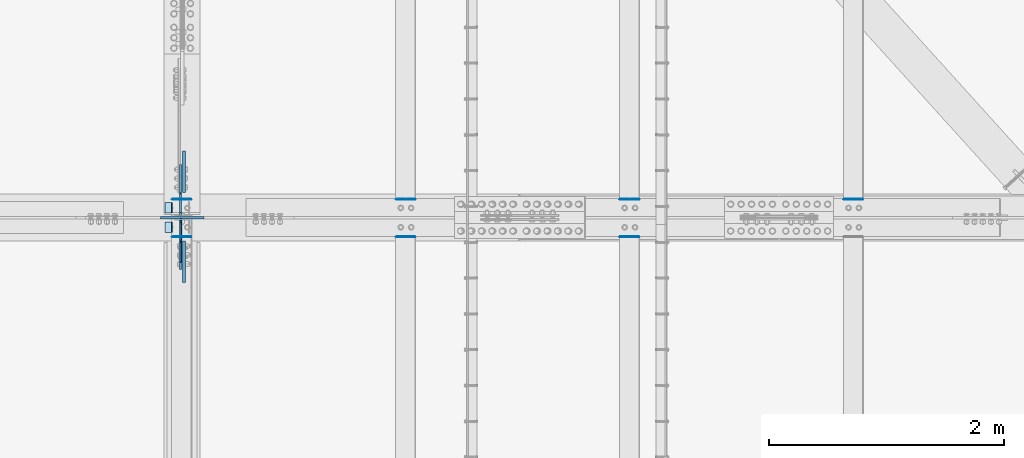
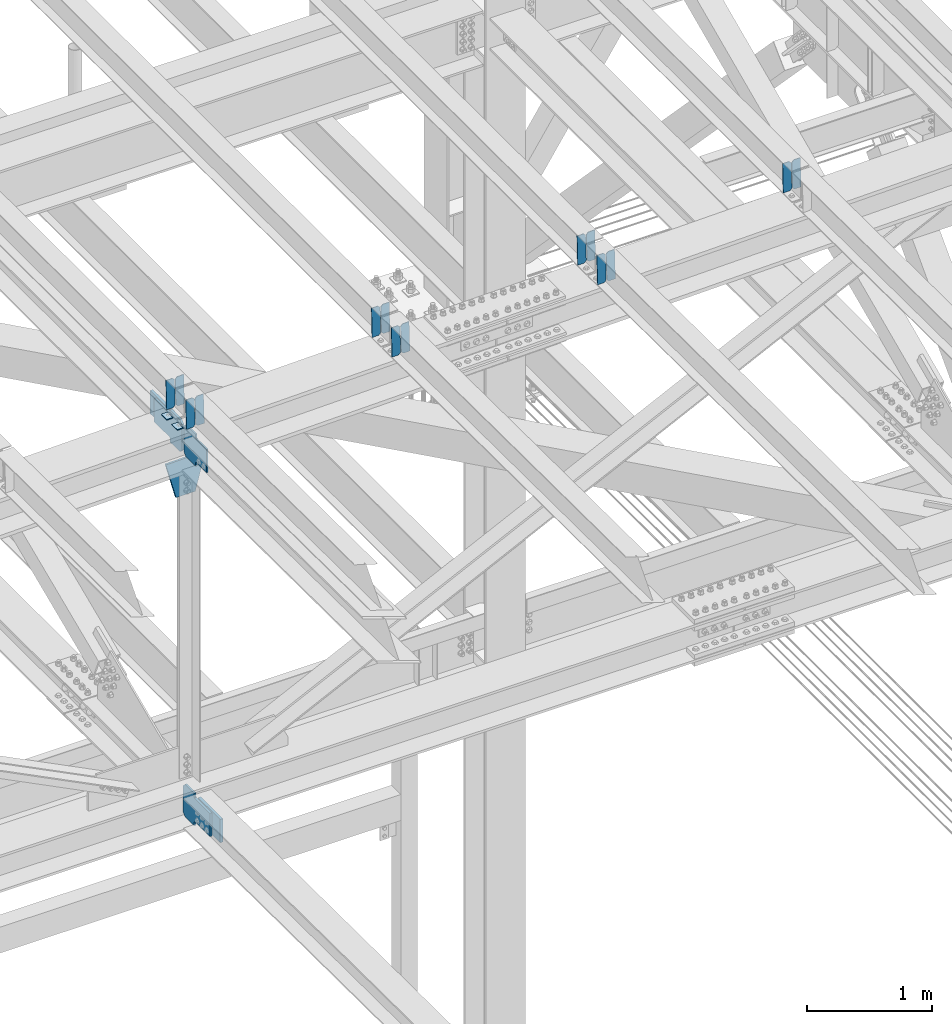
# One storey, part 3485 of 3843: 22 plates, 11 elements without a shape of their own.
"""IFC2X3 building model written with IfcOpenShell, lengths in millimetres."""

from ifc_helpers import new_model, si_unit, frame, origin_with_axes, place, context, subcontext, project, spatial, faceted_brep, material, type_object, element, aggregate, save


model = new_model("IFC2X3")

# Units and contexts
model_context = context("Model", 3, precision=1e-05, world=origin_with_axes())
body_context = subcontext(model_context, "Body", "Model", "MODEL_VIEW")
ifc_project = project(units=[si_unit("LENGTHUNIT", "METRE", prefix="MILLI"), si_unit("AREAUNIT", "SQUARE_METRE"), si_unit("VOLUMEUNIT", "CUBIC_METRE"), si_unit("MASSUNIT", "GRAM", prefix="KILO"), si_unit("TIMEUNIT", "SECOND"), si_unit("PLANEANGLEUNIT", "RADIAN"), si_unit("SOLIDANGLEUNIT", "STERADIAN"), si_unit("THERMODYNAMICTEMPERATUREUNIT", "DEGREE_CELSIUS"), si_unit("LUMINOUSINTENSITYUNIT", "LUMEN")], contexts=[model_context])

# Site, building, storey
site_placement = place(None, origin_with_axes())
site = spatial("IfcSite", under=ifc_project, at=site_placement, CompositionType="ELEMENT")
building_placement = place(site_placement, origin_with_axes())
building = spatial("IfcBuilding", under=site, at=building_placement, Name="Undefined", CompositionType="ELEMENT")
storey_placement = place(building_placement, origin_with_axes())
storey = spatial("IfcBuildingStorey", under=building, at=storey_placement, Name="Undefined", CompositionType="ELEMENT", Elevation=0.0)

# Assembly, plates
assembly_1_placement = place(storey_placement, origin_with_axes())
assembly_1 = element("IfcElementAssembly", 1, at=assembly_1_placement, inside=storey, Name="BEAM", AssemblyPlace="NOTDEFINED", PredefinedType="RIGID_FRAME")
ifc_material = material(Name="STEEL/A572-50")
plate_type_1 = type_object("IfcPlateType", PredefinedType="NOTDEFINED")
plate_1_placement = place(assembly_1_placement, frame((62718.6964783433, 84140.2504625903, 45994.9395738487), z_axis=(-0.0211520984080562, 0.00142216699976416, 0.999775257832459), x_axis=(-0.999776269338764, -3.00889999762259e-05, -0.021152077007147)))
plate_1 = element("IfcPlate", 2, at=plate_1_placement, type_object=plate_type_1, material=ifc_material, Name="PLATE", context=body_context, shape_type="Brep", body=[
    faceted_brep([(0.0, -3.17499999999927, 0.0), (6.83940015733242e-10, -3.17499999996653, 288.924999998613), (6.54836185276508e-10, 3.17500000001746, 288.924999998591), (0.0, 3.17499999999927, 0.0), (60.3250007643655, -3.17500000017753, 288.924999998606), (60.3250007643219, 3.17499999979918, 288.924999998584), (79.3750000013097, -3.17500000025029, 269.875000761494), (79.375000001266, 3.17499999972642, 269.875000761487), (79.375000000713, -3.17500000026484, 19.0499992370605), (79.3750000006985, 3.17499999971187, 19.0499992370533), (60.325000763667, -3.17500000020664, -1.45519152283669e-11), (60.3250007636234, 3.17499999977736, -3.63797880709171e-11)], [[[0, 1, 2, 3]], [[1, 4, 5, 2]], [[4, 6, 7, 5]], [[6, 8, 9, 7]], [[8, 10, 11, 9]], [[10, 0, 3, 11]], [[5, 7, 9, 11, 3, 2]], [[10, 8, 6, 4, 1, 0]]]),
])
plate_2_placement = place(assembly_1_placement, frame((62632.9906576536, 84140.2478832486, 45993.1263120825), z_axis=(-0.0211520984080562, 0.00142216699976416, 0.999775257832459), x_axis=(-0.999776269338764, -3.00889999762259e-05, -0.021152077007147)))
plate_2 = element("IfcPlate", 3, at=plate_2_placement, type_object=plate_type_1, material=ifc_material, Name="PLATE", context=body_context, shape_type="Brep", body=[
    faceted_brep([(4.36557456851006e-11, -3.17499999998836, 19.0499992370969), (6.11180439591408e-10, -3.17499999996653, 269.875000761516), (5.96628524363041e-10, 3.17500000001746, 269.875000761502), (1.45519152283669e-11, 3.17499999998836, 19.0499992370824), (19.0499992376572, -3.17500000003201, 288.924999998606), (19.0499992376281, 3.1749999999447, 288.924999998584), (79.3750000013242, -3.17500000025029, 288.924999998591), (79.3750000013097, 3.1749999997337, 288.92499999857), (79.3750000006548, -3.17500000026484, -2.18278728425503e-11), (79.3750000006403, 3.17499999969732, -2.91038304567337e-11), (19.0499992370023, -3.17500000005384, 0.0), (19.0499992369587, 3.17499999992287, -1.45519152283669e-11)], [[[0, 1, 2, 3]], [[1, 4, 5, 2]], [[4, 6, 7, 5]], [[6, 8, 9, 7]], [[8, 10, 11, 9]], [[10, 0, 3, 11]], [[5, 7, 9, 11, 3, 2]], [[10, 8, 6, 4, 1, 0]]]),
])

assembly_2_placement = place(storey_placement, origin_with_axes())
assembly_2 = element("IfcElementAssembly", 4, at=assembly_2_placement, inside=storey, Name="BEAM", AssemblyPlace="NOTDEFINED", PredefinedType="RIGID_FRAME")
plate_3_placement = place(assembly_2_placement, frame((62718.6964783431, 83820.8202545318, 45996.4634356429), z_axis=(-0.0211520980825589, 0.00792817899846704, 0.999744833807344), x_axis=(-0.99977626934565, -0.00016773499999526, -0.021151433007337)))
plate_3 = element("IfcPlate", 5, at=plate_3_placement, type_object=plate_type_1, material=ifc_material, Name="PLATE", context=body_context, shape_type="Brep", body=[
    faceted_brep([(0.0, -3.17499999999927, 0.0), (6.83940015733242e-10, -3.17499999996653, 288.924999998613), (6.54836185276508e-10, 3.17500000001746, 288.924999998591), (0.0, 3.17499999999927, 0.0), (60.3250007643655, -3.17500000017753, 288.924999998606), (60.3250007643219, 3.17499999979918, 288.924999998584), (79.3750000013097, -3.17500000025029, 269.875000761494), (79.375000001266, 3.17499999972642, 269.875000761487), (79.375000000713, -3.17500000026484, 19.0499992370605), (79.3750000006985, 3.17499999971187, 19.0499992370533), (60.325000763667, -3.17500000020664, -1.45519152283669e-11), (60.3250007636234, 3.17499999977736, -3.63797880709171e-11)], [[[0, 1, 2, 3]], [[1, 4, 5, 2]], [[4, 6, 7, 5]], [[6, 8, 9, 7]], [[8, 10, 11, 9]], [[10, 0, 3, 11]], [[5, 7, 9, 11, 3, 2]], [[10, 8, 6, 4, 1, 0]]]),
])
plate_4_placement = place(assembly_2_placement, frame((62632.9906576534, 83820.8058754357, 45994.6502290555), z_axis=(-0.0211520980825589, 0.00792817899846704, 0.999744833807344), x_axis=(-0.99977626934565, -0.00016773499999526, -0.021151433007337)))
plate_4 = element("IfcPlate", 6, at=plate_4_placement, type_object=plate_type_1, material=ifc_material, Name="PLATE", context=body_context, shape_type="Brep", body=[
    faceted_brep([(4.36557456851006e-11, -3.17499999998836, 19.0499992370969), (6.11180439591408e-10, -3.17499999996653, 269.875000761516), (5.96628524363041e-10, 3.17500000001746, 269.875000761502), (1.45519152283669e-11, 3.17499999998836, 19.0499992370824), (19.0499992376572, -3.17500000003201, 288.924999998606), (19.0499992376281, 3.1749999999447, 288.924999998584), (79.3750000013242, -3.17500000025029, 288.924999998591), (79.3750000013097, 3.1749999997337, 288.92499999857), (79.3750000006548, -3.17500000026484, -2.18278728425503e-11), (79.3750000006403, 3.17499999969732, -2.91038304567337e-11), (19.0499992370023, -3.17500000005384, 0.0), (19.0499992369587, 3.17499999992287, -1.45519152283669e-11)], [[[0, 1, 2, 3]], [[1, 4, 5, 2]], [[4, 6, 7, 5]], [[6, 8, 9, 7]], [[8, 10, 11, 9]], [[10, 0, 3, 11]], [[5, 7, 9, 11, 3, 2]], [[10, 8, 6, 4, 1, 0]]]),
])

assembly_3_placement = place(storey_placement, origin_with_axes())
assembly_3 = element("IfcElementAssembly", 7, at=assembly_3_placement, inside=storey, Name="BEAM", AssemblyPlace="NOTDEFINED", PredefinedType="RIGID_FRAME")
plate_5_placement = place(assembly_3_placement, frame((68433.6964783456, 84140.1572775966, 46118.5600129776), z_axis=(-0.0211520978230692, 0.00173404499923344, 0.999774765557535), x_axis=(-0.99977626935114, -3.66870000375661e-05, -0.0211520660073899)))
plate_5 = element("IfcPlate", 8, at=plate_5_placement, type_object=plate_type_1, material=ifc_material, Name="PLATE", context=body_context, shape_type="Brep", body=[
    faceted_brep([(0.0, -3.17499999999927, 0.0), (6.83940015733242e-10, -3.17499999996653, 288.924999998613), (6.54836185276508e-10, 3.17500000001746, 288.924999998591), (0.0, 3.17499999999927, 0.0), (60.3250007643655, -3.17500000017753, 288.924999998606), (60.3250007643219, 3.17499999979918, 288.924999998584), (79.3750000013097, -3.17500000025029, 269.875000761494), (79.375000001266, 3.17499999972642, 269.875000761487), (79.375000000713, -3.17500000026484, 19.0499992370605), (79.3750000006985, 3.17499999971187, 19.0499992370533), (60.325000763667, -3.17500000020664, -1.45519152283669e-11), (60.3250007636234, 3.17499999977736, -3.63797880709171e-11)], [[[0, 1, 2, 3]], [[1, 4, 5, 2]], [[4, 6, 7, 5]], [[6, 8, 9, 7]], [[8, 10, 11, 9]], [[10, 0, 3, 11]], [[5, 7, 9, 11, 3, 2]], [[10, 8, 6, 4, 1, 0]]]),
])
plate_6_placement = place(assembly_3_placement, frame((68347.9906576544, 84140.1541326133, 46116.7467521051), z_axis=(-0.0211520978230692, 0.00173404499923344, 0.999774765557535), x_axis=(-0.99977626935114, -3.66870000375661e-05, -0.0211520660073899)))
plate_6 = element("IfcPlate", 9, at=plate_6_placement, type_object=plate_type_1, material=ifc_material, Name="PLATE", context=body_context, shape_type="Brep", body=[
    faceted_brep([(4.36557456851006e-11, -3.17499999998836, 19.0499992370969), (6.11180439591408e-10, -3.17499999996653, 269.875000761516), (5.96628524363041e-10, 3.17500000001746, 269.875000761502), (1.45519152283669e-11, 3.17499999998836, 19.0499992370824), (19.0499992376572, -3.17500000003201, 288.924999998606), (19.0499992376281, 3.1749999999447, 288.924999998584), (79.3750000013242, -3.17500000025029, 288.924999998591), (79.3750000013097, 3.1749999997337, 288.92499999857), (79.3750000006548, -3.17500000026484, -2.18278728425503e-11), (79.3750000006403, 3.17499999969732, -2.91038304567337e-11), (19.0499992370023, -3.17500000005384, 0.0), (19.0499992369587, 3.17499999992287, -1.45519152283669e-11)], [[[0, 1, 2, 3]], [[1, 4, 5, 2]], [[4, 6, 7, 5]], [[6, 8, 9, 7]], [[8, 10, 11, 9]], [[10, 0, 3, 11]], [[5, 7, 9, 11, 3, 2]], [[10, 8, 6, 4, 1, 0]]]),
])
aggregate(assembly_3, [plate_5, plate_6])

assembly_4_placement = place(storey_placement, origin_with_axes())
assembly_4 = element("IfcElementAssembly", 10, at=assembly_4_placement, inside=storey, Name="BEAM", AssemblyPlace="NOTDEFINED", PredefinedType="RIGID_FRAME")
plate_7_placement = place(assembly_4_placement, frame((66528.6964783469, 84140.1883425519, 46077.3531965113), z_axis=(-0.0211520981216017, 0.00163008600074681, 0.999774940456443), x_axis=(-0.999776269344824, -3.44869999710776e-05, -0.0211520700072795)))
plate_7 = element("IfcPlate", 11, at=plate_7_placement, type_object=plate_type_1, material=ifc_material, Name="PLATE", context=body_context, shape_type="Brep", body=[
    faceted_brep([(0.0, -3.17499999999927, 0.0), (6.83940015733242e-10, -3.17499999996653, 288.924999998613), (6.54836185276508e-10, 3.17500000001746, 288.924999998591), (0.0, 3.17499999999927, 0.0), (60.3250007643655, -3.17500000017753, 288.924999998606), (60.3250007643219, 3.17499999979918, 288.924999998584), (79.3750000013097, -3.17500000025029, 269.875000761494), (79.375000001266, 3.17499999972642, 269.875000761487), (79.375000000713, -3.17500000026484, 19.0499992370605), (79.3750000006985, 3.17499999971187, 19.0499992370533), (60.325000763667, -3.17500000020664, -1.45519152283669e-11), (60.3250007636234, 3.17499999977736, -3.63797880709171e-11)], [[[0, 1, 2, 3]], [[1, 4, 5, 2]], [[4, 6, 7, 5]], [[6, 8, 9, 7]], [[8, 10, 11, 9]], [[10, 0, 3, 11]], [[5, 7, 9, 11, 3, 2]], [[10, 8, 6, 4, 1, 0]]]),
])
plate_8_placement = place(assembly_4_placement, frame((66442.9906576557, 84140.1853861144, 46075.5399353195), z_axis=(-0.0211520981216017, 0.00163008600074681, 0.999774940456443), x_axis=(-0.999776269344824, -3.44869999710776e-05, -0.0211520700072795)))
plate_8 = element("IfcPlate", 12, at=plate_8_placement, type_object=plate_type_1, material=ifc_material, Name="PLATE", context=body_context, shape_type="Brep", body=[
    faceted_brep([(4.36557456851006e-11, -3.17499999998836, 19.0499992370969), (6.11180439591408e-10, -3.17499999996653, 269.875000761516), (5.96628524363041e-10, 3.17500000001746, 269.875000761502), (1.45519152283669e-11, 3.17499999998836, 19.0499992370824), (19.0499992376572, -3.17500000003201, 288.924999998606), (19.0499992376281, 3.1749999999447, 288.924999998584), (79.3750000013242, -3.17500000025029, 288.924999998591), (79.3750000013097, 3.1749999997337, 288.92499999857), (79.3750000006548, -3.17500000026484, -2.18278728425503e-11), (79.3750000006403, 3.17499999969732, -2.91038304567337e-11), (19.0499992370023, -3.17500000005384, 0.0), (19.0499992369587, 3.17499999992287, -1.45519152283669e-11)], [[[0, 1, 2, 3]], [[1, 4, 5, 2]], [[4, 6, 7, 5]], [[6, 8, 9, 7]], [[8, 10, 11, 9]], [[10, 0, 3, 11]], [[5, 7, 9, 11, 3, 2]], [[10, 8, 6, 4, 1, 0]]]),
])
aggregate(assembly_4, [plate_7, plate_8])

assembly_5_placement = place(storey_placement, origin_with_axes())
assembly_5 = element("IfcElementAssembly", 13, at=assembly_5_placement, inside=storey, Name="BEAM", AssemblyPlace="NOTDEFINED", PredefinedType="RIGID_FRAME")
plate_9_placement = place(assembly_5_placement, frame((66528.6964783481, 83820.8212350225, 46078.9086635965), z_axis=(-0.0211520975278255, 0.0079248620009312, 0.99974486011804), x_axis=(-0.99977626934565, -0.00016773499999526, -0.021151433007337)))
plate_9 = element("IfcPlate", 14, at=plate_9_placement, type_object=plate_type_1, material=ifc_material, Name="PLATE", context=body_context, shape_type="Brep", body=[
    faceted_brep([(0.0, -3.17499999999927, 0.0), (6.83940015733242e-10, -3.17499999996653, 288.924999998613), (6.54836185276508e-10, 3.17500000001746, 288.924999998591), (0.0, 3.17499999999927, 0.0), (60.3250007643655, -3.17500000017753, 288.924999998606), (60.3250007643219, 3.17499999979918, 288.924999998584), (79.3750000013097, -3.17500000025029, 269.875000761494), (79.375000001266, 3.17499999972642, 269.875000761487), (79.375000000713, -3.17500000026484, 19.0499992370605), (79.3750000006985, 3.17499999971187, 19.0499992370533), (60.325000763667, -3.17500000020664, -1.45519152283669e-11), (60.3250007636234, 3.17499999977736, -3.63797880709171e-11)], [[[0, 1, 2, 3]], [[1, 4, 5, 2]], [[4, 6, 7, 5]], [[6, 8, 9, 7]], [[8, 10, 11, 9]], [[10, 0, 3, 11]], [[5, 7, 9, 11, 3, 2]], [[10, 8, 6, 4, 1, 0]]]),
])
plate_10_placement = place(assembly_5_placement, frame((66442.9906576568, 83820.8068619417, 46077.0954569614), z_axis=(-0.0211520975278255, 0.0079248620009312, 0.99974486011804), x_axis=(-0.99977626934565, -0.00016773499999526, -0.021151433007337)))
plate_10 = element("IfcPlate", 15, at=plate_10_placement, type_object=plate_type_1, material=ifc_material, Name="PLATE", context=body_context, shape_type="Brep", body=[
    faceted_brep([(4.36557456851006e-11, -3.17499999998836, 19.0499992370969), (6.11180439591408e-10, -3.17499999996653, 269.875000761516), (5.96628524363041e-10, 3.17500000001746, 269.875000761502), (1.45519152283669e-11, 3.17499999998836, 19.0499992370824), (19.0499992376572, -3.17500000003201, 288.924999998606), (19.0499992376281, 3.1749999999447, 288.924999998584), (79.3750000013242, -3.17500000025029, 288.924999998591), (79.3750000013097, 3.1749999997337, 288.92499999857), (79.3750000006548, -3.17500000026484, -2.18278728425503e-11), (79.3750000006403, 3.17499999969732, -2.91038304567337e-11), (19.0499992370023, -3.17500000005384, 0.0), (19.0499992369587, 3.17499999992287, -1.45519152283669e-11)], [[[0, 1, 2, 3]], [[1, 4, 5, 2]], [[4, 6, 7, 5]], [[6, 8, 9, 7]], [[8, 10, 11, 9]], [[10, 0, 3, 11]], [[5, 7, 9, 11, 3, 2]], [[10, 8, 6, 4, 1, 0]]]),
])
aggregate(assembly_5, [plate_9, plate_10])

assembly_6_placement = place(storey_placement, origin_with_axes())
assembly_6 = element("IfcElementAssembly", 16, at=assembly_6_placement, inside=storey, Name="BEAM", AssemblyPlace="NOTDEFINED", PredefinedType="RIGID_FRAME")
plate_11_placement = place(assembly_6_placement, frame((64623.6964783431, 84140.2194041178, 46036.1463842223), z_axis=(-0.0211520976508109, 0.00152612699933525, 0.999775104561697), x_axis=(-0.999776269354785, -3.22879999736168e-05, -0.0211520730074938)))
plate_11 = element("IfcPlate", 17, at=plate_11_placement, type_object=plate_type_1, material=ifc_material, Name="PLATE", context=body_context, shape_type="Brep", body=[
    faceted_brep([(0.0, -3.17499999999927, 0.0), (6.83940015733242e-10, -3.17499999996653, 288.924999998613), (6.54836185276508e-10, 3.17500000001746, 288.924999998591), (0.0, 3.17499999999927, 0.0), (60.3250007643655, -3.17500000017753, 288.924999998606), (60.3250007643219, 3.17499999979918, 288.924999998584), (79.3750000013097, -3.17500000025029, 269.875000761494), (79.375000001266, 3.17499999972642, 269.875000761487), (79.375000000713, -3.17500000026484, 19.0499992370605), (79.3750000006985, 3.17499999971187, 19.0499992370533), (60.325000763667, -3.17500000020664, -1.45519152283669e-11), (60.3250007636234, 3.17499999977736, -3.63797880709171e-11)], [[[0, 1, 2, 3]], [[1, 4, 5, 2]], [[4, 6, 7, 5]], [[6, 8, 9, 7]], [[8, 10, 11, 9]], [[10, 0, 3, 11]], [[5, 7, 9, 11, 3, 2]], [[10, 8, 6, 4, 1, 0]]]),
])
plate_12_placement = place(assembly_6_placement, frame((64537.9906576538, 84140.2166362268, 46034.3331227344), z_axis=(-0.0211520976508109, 0.00152612699933525, 0.999775104561697), x_axis=(-0.999776269354785, -3.22879999736168e-05, -0.0211520730074938)))
plate_12 = element("IfcPlate", 18, at=plate_12_placement, type_object=plate_type_1, material=ifc_material, Name="PLATE", context=body_context, shape_type="Brep", body=[
    faceted_brep([(4.36557456851006e-11, -3.17499999998836, 19.0499992370969), (6.11180439591408e-10, -3.17499999996653, 269.875000761516), (5.96628524363041e-10, 3.17500000001746, 269.875000761502), (1.45519152283669e-11, 3.17499999998836, 19.0499992370824), (19.0499992376572, -3.17500000003201, 288.924999998606), (19.0499992376281, 3.1749999999447, 288.924999998584), (79.3750000013242, -3.17500000025029, 288.924999998591), (79.3750000013097, 3.1749999997337, 288.92499999857), (79.3750000006548, -3.17500000026484, -2.18278728425503e-11), (79.3750000006403, 3.17499999969732, -2.91038304567337e-11), (19.0499992370023, -3.17500000005384, 0.0), (19.0499992369587, 3.17499999992287, -1.45519152283669e-11)], [[[0, 1, 2, 3]], [[1, 4, 5, 2]], [[4, 6, 7, 5]], [[6, 8, 9, 7]], [[8, 10, 11, 9]], [[10, 0, 3, 11]], [[5, 7, 9, 11, 3, 2]], [[10, 8, 6, 4, 1, 0]]]),
])
aggregate(assembly_6, [plate_11, plate_12])

assembly_7_placement = place(storey_placement, origin_with_axes())
assembly_7 = element("IfcElementAssembly", 19, at=assembly_7_placement, inside=storey, Name="BEAM", AssemblyPlace="NOTDEFINED", PredefinedType="RIGID_FRAME")
plate_13_placement = place(assembly_7_placement, frame((64623.6964818075, 83820.8082052274, 46037.6931278537), z_axis=(-0.0211520981591165, 0.00796893299830843, 0.999744509787543), x_axis=(-0.99977626934565, -0.00016773499999526, -0.021151433007337)))
plate_13 = element("IfcPlate", 20, at=plate_13_placement, type_object=plate_type_1, material=ifc_material, Name="PLATE", context=body_context, shape_type="Brep", body=[
    faceted_brep([(0.0, -3.17499999999927, 0.0), (6.83940015733242e-10, -3.17499999996653, 288.924999998613), (6.54836185276508e-10, 3.17500000001746, 288.924999998591), (0.0, 3.17499999999927, 0.0), (60.3250007643655, -3.17500000017753, 288.924999998606), (60.3250007643219, 3.17499999979918, 288.924999998584), (79.3750000013097, -3.17500000025029, 269.875000761494), (79.375000001266, 3.17499999972642, 269.875000761487), (79.375000000713, -3.17500000026484, 19.0499992370605), (79.3750000006985, 3.17499999971187, 19.0499992370533), (60.325000763667, -3.17500000020664, -1.45519152283669e-11), (60.3250007636234, 3.17499999977736, -3.63797880709171e-11)], [[[0, 1, 2, 3]], [[1, 4, 5, 2]], [[4, 6, 7, 5]], [[6, 8, 9, 7]], [[8, 10, 11, 9]], [[10, 0, 3, 11]], [[5, 7, 9, 11, 3, 2]], [[10, 8, 6, 4, 1, 0]]]),
])
plate_14_placement = place(assembly_7_placement, frame((64537.9906611181, 83820.7937498166, 46035.8799218732), z_axis=(-0.0211520981591165, 0.00796893299830843, 0.999744509787543), x_axis=(-0.99977626934565, -0.00016773499999526, -0.021151433007337)))
plate_14 = element("IfcPlate", 21, at=plate_14_placement, type_object=plate_type_1, material=ifc_material, Name="PLATE", context=body_context, shape_type="Brep", body=[
    faceted_brep([(4.36557456851006e-11, -3.17499999998836, 19.0499992370969), (6.11180439591408e-10, -3.17499999996653, 269.875000761516), (5.96628524363041e-10, 3.17500000001746, 269.875000761502), (1.45519152283669e-11, 3.17499999998836, 19.0499992370824), (19.0499992376572, -3.17500000003201, 288.924999998606), (19.0499992376281, 3.1749999999447, 288.924999998584), (79.3750000013242, -3.17500000025029, 288.924999998591), (79.3750000013097, 3.1749999997337, 288.92499999857), (79.3750000006548, -3.17500000026484, -2.18278728425503e-11), (79.3750000006403, 3.17499999969732, -2.91038304567337e-11), (19.0499992370023, -3.17500000005384, 0.0), (19.0499992369587, 3.17499999992287, -1.45519152283669e-11)], [[[0, 1, 2, 3]], [[1, 4, 5, 2]], [[4, 6, 7, 5]], [[6, 8, 9, 7]], [[8, 10, 11, 9]], [[10, 0, 3, 11]], [[5, 7, 9, 11, 3, 2]], [[10, 8, 6, 4, 1, 0]]]),
])
aggregate(assembly_7, [plate_13, plate_14])

# Plate
plate_type_2 = type_object("IfcPlateType", PredefinedType="NOTDEFINED")
plate_15_placement = place(assembly_1_placement, frame((62553.7677288857, 84112.0999999999, 45985.3196287684), z_axis=(0.0, -1.0, 0.0), x_axis=(-0.999776270257024, 0.0, -0.0211520550054595)))
plate_15 = element("IfcPlate", 22, at=plate_15_placement, type_object=plate_type_2, material=ifc_material, Name="PLATE", context=body_context, shape_type="Brep", body=[
    faceted_brep([(9.52499999982683, -4.7625000001135, 88.8999999999942), (0.0, 4.76249999999709, 88.9000015258789), (0.0, 4.76249999999709, 0.0), (9.52499999981956, -4.76249999999709, 0.0), (63.4999984608512, -4.76249999988795, 88.8999999999796), (63.4999984608367, -4.76249999988795, -1.45519152283669e-11), (63.4999984608221, 4.76250000013533, -1.45519152283669e-11), (63.4999984608367, 4.76250000013533, 88.8999999999796)], [[[0, 1, 2, 3]], [[4, 5, 6, 7]], [[5, 4, 0, 3]], [[6, 5, 3, 2]], [[7, 6, 2, 1]], [[4, 7, 1, 0]]]),
])

aggregate(assembly_1, [plate_1, plate_2, plate_15])

plate_16_placement = place(assembly_2_placement, frame((62553.7677288857, 83947.0000015258, 45985.3196287684), z_axis=(0.0, -1.0, 0.0), x_axis=(-0.999776270257024, 0.0, -0.0211520550054595)))
plate_16 = element("IfcPlate", 23, at=plate_16_placement, type_object=plate_type_2, material=ifc_material, Name="PLATE", context=body_context, shape_type="Brep", body=[
    faceted_brep([(9.52499999982683, -4.7625000001135, 88.8999999999942), (0.0, 4.76249999999709, 88.9000015258789), (0.0, 4.76249999999709, 0.0), (9.52499999981956, -4.76249999999709, 0.0), (63.4999984608512, -4.76249999988795, 88.8999999999796), (63.4999984608367, -4.76249999988795, -1.45519152283669e-11), (63.4999984608221, 4.76250000013533, -1.45519152283669e-11), (63.4999984608367, 4.76250000013533, 88.8999999999796)], [[[0, 1, 2, 3]], [[4, 5, 6, 7]], [[5, 4, 0, 3]], [[6, 5, 3, 2]], [[7, 6, 2, 1]], [[4, 7, 1, 0]]]),
])

aggregate(assembly_2, [plate_3, plate_4, plate_16])

# Assembly, plate
assembly_8_placement = place(storey_placement, origin_with_axes())
assembly_8 = element("IfcElementAssembly", 24, at=assembly_8_placement, inside=storey, Name="BEAM", AssemblyPlace="NOTDEFINED", PredefinedType="RIGID_FRAME")
plate_type_3 = type_object("IfcPlateType", PredefinedType="NOTDEFINED")
plate_17_placement = place(assembly_8_placement, frame((62625.2874999616, 83973.9874999387, 45658.2674651113), z_axis=(0.0, -0.707106781186682, 0.707106781186413), x_axis=(0.0, -0.707106781186548, -0.707106781186548)))
plate_17 = element("IfcPlate", 25, at=plate_17_placement, type_object=plate_type_3, material=ifc_material, Name="PLATE", context=body_context, shape_type="Brep", body=[
    faceted_brep([(0.0, -6.3499999046162, 0.0), (-179.46387894213, -6.35000000000582, 179.46387894213), (-179.46387894213, 6.35000000000582, 179.46387894213), (7.27595761418343e-12, 6.3499999046162, 0.0), (-179.463878941897, -6.35000000000582, 224.365159547495), (-179.463878941897, 6.35000000000582, 224.365159547495), (-68.3332094431244, -6.35000000000582, 335.495829046271), (-68.3332094431244, 6.35000000000582, 335.495829046271), (-47.5652940833388, -6.34999999999854, 314.727913657542), (-47.5652940833388, 6.34999999999854, 314.727913657542), (-43.4451176151779, -6.34999999999854, 311.974899757079), (-43.4451176151779, 6.34999999999854, 311.974899757079), (-38.5850380971242, -6.34999999999854, 311.008169834509), (-38.5850380971242, 6.34999999999854, 311.008169834509), (-33.724958579056, -6.34999999999854, 311.97489975713), (-33.724958579056, 6.34999999999854, 311.97489975713), (-29.6047821108805, -6.34999999999854, 314.72791365764), (-29.6047821108805, 6.34999999999854, 314.72791365764), (87.138547615672, -6.34999999999854, 431.471243384221), (87.138547615672, 6.34999999999854, 431.471243384221), (248.78315779414, -6.34999999999854, 269.826633205768), (248.78315779414, 6.34999999999854, 269.826633205768), (132.039828067587, -6.34999999999854, 153.083303479179), (132.039828067587, 6.34999999999854, 153.083303479179), (129.286814167077, -6.34999999999854, 148.963127011004), (129.286814167077, 6.34999999999854, 148.963127011004), (128.320084244464, -6.34999999999854, 144.103047492936), (128.320084244464, 6.34999999999854, 144.103047492936), (129.286814167019, -6.34999999999854, 139.242967974889), (129.286814167019, 6.34999999999854, 139.242967974889), (132.0398280675, -6.34999999999854, 135.122791506732), (132.0398280675, 6.34999999999854, 135.122791506732), (156.031950102829, -6.35000000000582, 111.130669497703), (156.031950102829, 6.35000000000582, 111.130669497703), (44.9012806051323, -6.35000000000582, -1.45519152283669e-11), (44.9012806051323, 6.35000000000582, -1.45519152283669e-11)], [[[0, 1, 2, 3]], [[1, 4, 5, 2]], [[4, 6, 7, 5]], [[6, 8, 9, 7]], [[8, 10, 11, 9]], [[10, 12, 13, 11]], [[12, 14, 15, 13]], [[14, 16, 17, 15]], [[16, 18, 19, 17]], [[18, 20, 21, 19]], [[20, 22, 23, 21]], [[22, 24, 25, 23]], [[24, 26, 27, 25]], [[26, 28, 29, 27]], [[28, 30, 31, 29]], [[30, 32, 33, 31]], [[32, 34, 35, 33]], [[34, 0, 3, 35]], [[5, 7, 9, 11, 13, 15, 17, 19, 21, 23, 25, 27, 29, 31, 33, 35, 3, 2]], [[34, 32, 30, 28, 26, 24, 22, 20, 18, 16, 14, 12, 10, 8, 6, 4, 1, 0]]]),
])

assembly_9_placement = place(storey_placement, origin_with_axes())
assembly_9 = element("IfcElementAssembly", 26, at=assembly_9_placement, inside=storey, Name="BEAM", AssemblyPlace="NOTDEFINED", PredefinedType="RIGID_FRAME")
plate_type_4 = type_object("IfcPlateType", PredefinedType="NOTDEFINED")
plate_18_placement = place(assembly_9_placement, frame((62622.1124996199, 83977.9562500442, 42132.1300352291), z_axis=(0.0, -0.707106781186682, 0.707106781186413), x_axis=(0.0, -0.707106781186548, -0.707106781186548)))
plate_18 = element("IfcPlate", 27, at=plate_18_placement, type_object=plate_type_4, material=ifc_material, Name="PLATE", context=body_context, shape_type="Brep", body=[
    faceted_brep([(0.0, -9.52500000000146, 0.0), (-179.598645145647, -9.52500000000146, 179.598645145648), (-179.598645145647, 9.52500000000146, 179.598645145648), (0.0, 9.52500000000146, 0.0), (-179.59864514565, -9.52500000000146, 224.499925750773), (-179.59864514565, 9.52500000000146, 224.499925750773), (-75.7644337462789, -9.52500000000146, 328.33413715013), (-75.7644337462789, 9.52500000000146, 328.33413715013), (-54.6832751731854, -9.52500000000146, 307.252978541605), (-54.6832751731854, 9.52500000000146, 307.252978541605), (-50.5630987050245, -9.52500000000146, 304.499964641138), (-50.5630987050245, 9.52500000000146, 304.499964641138), (-45.7030191869708, -9.52500000000146, 303.533234718569), (-45.7030191869708, 9.52500000000146, 303.533234718569), (-40.8429396689025, -9.52500000000146, 304.499964641185), (-40.8429396689025, 9.52500000000146, 304.499964641185), (-36.7227632007271, -9.52500000000146, 307.252978541692), (-36.7227632007271, 9.52500000000146, 307.252978541692), (133.902103257569, -9.52500000000146, 477.877844999945), (133.902103257569, 9.52500000000146, 477.877844999945), (295.546713436022, -9.52500000000146, 316.233234821455), (295.546713436022, 9.52500000000146, 316.233234821455), (124.921846977726, -9.52500000000146, 145.608368363202), (124.921846977726, 9.52500000000146, 145.608368363202), (122.168833077216, -9.52500000000146, 141.488191895023), (122.168833077216, 9.52500000000146, 141.488191895023), (121.202103154603, -9.52500000000146, 136.628112376959), (121.202103154603, 9.52500000000146, 136.628112376959), (122.168833077158, -9.52500000000146, 131.768032858909), (122.168833077158, 9.52500000000146, 131.768032858909), (124.921846977624, -9.52500000000146, 127.647856390762), (124.921846977624, 9.52500000000146, 127.647856390762), (148.735492003645, -9.52499999999418, 103.834211398527), (148.735492003645, 9.52499999999418, 103.834211398527), (44.9012806055835, -9.52499999999418, 4.65661287307739e-10), (44.9012806055835, 9.52499999999418, 4.65661287307739e-10)], [[[0, 1, 2, 3]], [[1, 4, 5, 2]], [[4, 6, 7, 5]], [[6, 8, 9, 7]], [[8, 10, 11, 9]], [[10, 12, 13, 11]], [[12, 14, 15, 13]], [[14, 16, 17, 15]], [[16, 18, 19, 17]], [[18, 20, 21, 19]], [[20, 22, 23, 21]], [[22, 24, 25, 23]], [[24, 26, 27, 25]], [[26, 28, 29, 27]], [[28, 30, 31, 29]], [[30, 32, 33, 31]], [[32, 34, 35, 33]], [[34, 0, 3, 35]], [[5, 7, 9, 11, 13, 15, 17, 19, 21, 23, 25, 27, 29, 31, 33, 35, 3, 2]], [[34, 32, 30, 28, 26, 24, 22, 20, 18, 16, 14, 12, 10, 8, 6, 4, 1, 0]]]),
])
aggregate(assembly_9, [plate_18])

# Plate
plate_19_placement = place(assembly_8_placement, frame((62622.1124997216, 83996.2125, 45658.2674651706), z_axis=(0.0, 0.707106781186548, 0.707106781186548), x_axis=(5.70000238222118e-08, 0.707106781186546, -0.707106781186546)))
plate_19 = element("IfcPlate", 28, at=plate_19_placement, type_object=plate_type_4, material=ifc_material, Name="PLATE", context=body_context, shape_type="Brep", body=[
    faceted_brep([(0.0, -9.52500000000146, 0.0), (-179.366715657274, -9.52499999999418, 179.366715657248), (-179.366715657274, 9.52499999999418, 179.366715657248), (0.0, 9.52500000000146, 0.0), (-179.366715656826, -9.52499999999418, 224.267996262832), (-179.366715656826, 9.52499999999418, 224.267996262832), (-68.2360461568533, -9.52499999999418, 335.398665762827), (-68.2360461568533, 9.52499999999418, 335.398665762827), (-46.1232264977771, -9.52499999999418, 313.285846103783), (-46.1232264977771, 9.52499999999418, 313.285846103783), (-42.003050029638, -9.52499999999418, 310.532832203317), (-42.003050029638, 9.52499999999418, 310.532832203317), (-37.1429705115806, -9.52499999999418, 309.566102280762), (-37.1429705115806, 9.52499999999418, 309.566102280762), (-32.2828909935233, -9.52499999999418, 310.53283220336), (-32.2828909935233, 9.52499999999418, 310.53283220336), (-28.1627145253442, -9.52499999999418, 313.28584610387), (-28.1627145253442, 9.52499999999418, 313.28584610387), (142.462151912587, -9.52499999999418, 483.910712541838), (142.462151912587, 9.52499999999418, 483.910712541838), (304.106762091076, -9.52499999999418, 322.266102363385), (304.106762091076, 9.52499999999418, 322.266102363385), (133.481895653153, -9.52499999999418, 151.641235925432), (133.481895653153, 9.52499999999418, 151.641235925432), (130.728881752639, -9.52499999999418, 147.521059457242), (130.728881752639, 9.52499999999418, 147.521059457242), (129.762151830029, -9.52499999999418, 142.660979939188), (129.762151830029, 9.52499999999418, 142.660979939188), (130.728881752595, -9.52499999999418, 137.80090042112), (130.728881752595, 9.52499999999418, 137.80090042112), (133.481895653069, -9.52499999999418, 133.680723952973), (133.481895653069, 9.52499999999418, 133.680723952973), (156.031950102854, -9.52499999999418, 111.130669497732), (156.031950102854, 9.52499999999418, 111.130669497732), (44.9012806055835, -9.52499999999418, 4.65661287307739e-10), (44.9012806055835, 9.52499999999418, 4.65661287307739e-10)], [[[0, 1, 2, 3]], [[1, 4, 5, 2]], [[4, 6, 7, 5]], [[6, 8, 9, 7]], [[8, 10, 11, 9]], [[10, 12, 13, 11]], [[12, 14, 15, 13]], [[14, 16, 17, 15]], [[16, 18, 19, 17]], [[18, 20, 21, 19]], [[20, 22, 23, 21]], [[22, 24, 25, 23]], [[24, 26, 27, 25]], [[26, 28, 29, 27]], [[28, 30, 31, 29]], [[30, 32, 33, 31]], [[32, 34, 35, 33]], [[34, 0, 3, 35]], [[5, 7, 9, 11, 13, 15, 17, 19, 21, 23, 25, 27, 29, 31, 33, 35, 3, 2]], [[34, 32, 30, 28, 26, 24, 22, 20, 18, 16, 14, 12, 10, 8, 6, 4, 1, 0]]]),
])

# Assembly, plate
assembly_10_placement = place(storey_placement, origin_with_axes())
assembly_10 = element("IfcElementAssembly", 29, at=assembly_10_placement, inside=storey, Name="BEAM", AssemblyPlace="NOTDEFINED", PredefinedType="RIGID_FRAME")
plate_type_5 = type_object("IfcPlateType", PredefinedType="NOTDEFINED")
plate_20_placement = place(assembly_10_placement, frame((62653.8625000005, 83431.0625002607, 42375.3576148092), z_axis=(0.0, 0.0, -1.0), x_axis=(0.0, 1.0, 0.0)))
plate_20 = element("IfcPlate", 30, at=plate_20_placement, type_object=plate_type_5, material=ifc_material, Name="PLATE", context=body_context, shape_type="Brep", body=[
    faceted_brep([(0.0, -12.6999999999971, 0.0), (1.30967237055302e-10, -12.6999999999971, 228.600000023711), (1.30967237055302e-10, 12.6999999999971, 228.600000023711), (0.0, 12.6999999999971, 0.0), (355.600000000137, -12.6999999999971, 228.600000023711), (355.600000000137, 12.6999999999971, 228.600000023711), (355.599999999999, -12.7000000000007, 0.0), (355.599999999999, 12.7000000000007, 0.0)], [[[0, 1, 2, 3]], [[1, 4, 5, 2]], [[4, 6, 7, 5]], [[6, 0, 3, 7]], [[5, 7, 3, 2]], [[6, 4, 1, 0]]]),
])
aggregate(assembly_10, [plate_20])

assembly_11_placement = place(storey_placement, origin_with_axes())
assembly_11 = element("IfcElementAssembly", 31, at=assembly_11_placement, inside=storey, Name="BEAM", AssemblyPlace="NOTDEFINED", PredefinedType="RIGID_FRAME")
plate_21_placement = place(assembly_11_placement, frame((62653.8625085503, 84553.4249947554, 45671.1080578228), z_axis=(0.0, -1.0, 0.0), x_axis=(0.0, 0.0, 1.0)))
plate_21 = element("IfcPlate", 32, at=plate_21_placement, type_object=plate_type_5, material=ifc_material, Name="PLATE", context=body_context, shape_type="Brep", body=[
    faceted_brep([(0.0, -12.6999999999971, 0.0), (0.0, -12.7000000000007, 355.600000000006), (0.0, 12.7000000000007, 355.600000000006), (0.0, 12.6999999999971, 0.0), (228.599998464349, -12.7000000013795, 355.599999691767), (228.599998464349, 12.6999999986292, 355.599999691869), (228.599999999991, -12.7000007629103, -5.82076609134674e-10), (228.59998398881, 12.6999999999971, -9.82254277914762e-10)], [[[0, 1, 2, 3]], [[1, 4, 5, 2]], [[4, 6, 7, 5]], [[6, 0, 3, 7]], [[5, 7, 3, 2]], [[6, 4, 1, 0]]]),
])
aggregate(assembly_11, [plate_21])

# Plate
plate_type_6 = type_object("IfcPlateType", PredefinedType="NOTDEFINED")
plate_22_placement = place(assembly_8_placement, frame((62822.028833969, 83985.1, 45592.5288551444), z_axis=(0.0216342480057937, 0.0, -0.999765952267441), x_axis=(-0.999765952267441, 0.0, -0.0216342480057875)))
plate_22 = element("IfcPlate", 33, at=plate_22_placement, type_object=plate_type_6, material=ifc_material, Name="PLATE", context=body_context, shape_type="Brep", body=[
    faceted_brep([(0.0, -9.52500000000146, 0.0), (104.51609176374, -9.52500000000146, 358.819776832883), (104.51609176374, 9.52500000000146, 358.819776832883), (0.0, 9.52500000000146, 0.0), (282.274478078463, -9.52500000000146, 354.973207537645), (282.274478078463, 9.52500000000146, 354.973207537645), (369.203849118567, -9.52500000000146, 4.58385329693556e-10), (369.203849118567, 9.52500000000146, 4.58385329693556e-10)], [[[0, 1, 2, 3]], [[1, 4, 5, 2]], [[4, 6, 7, 5]], [[6, 0, 3, 7]], [[5, 7, 3, 2]], [[6, 4, 1, 0]]]),
])

aggregate(assembly_8, [plate_19, plate_17, plate_22])

save(model, "model.ifc")
